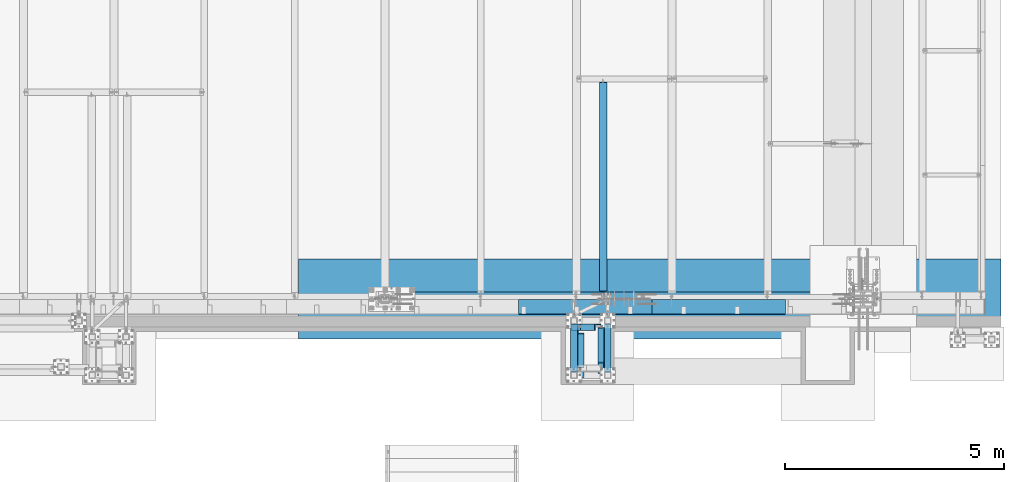
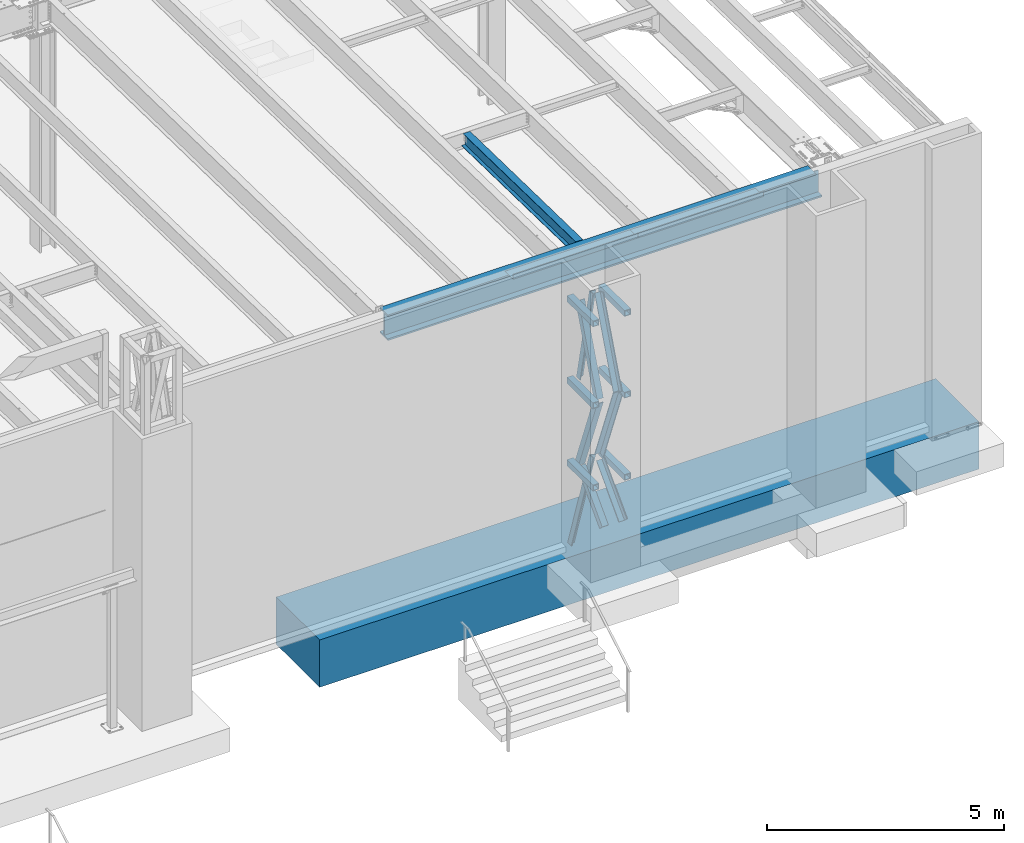
# One storey, part 1110 of 1763: 11 beams, 8 members, 4 elements without a shape of their own.
"""IFC2X3 building model written with IfcOpenShell, lengths in millimetres."""

from ifc_helpers import new_model, si_unit, frame, origin_with_axes, place, context, subcontext, project, spatial, faceted_brep, material, type_object, element, aggregate, save


model = new_model("IFC2X3")

# Units and contexts
model_context = context("Model", 3, precision=1e-05, world=origin_with_axes())
body_context = subcontext(model_context, "Body", "Model", "MODEL_VIEW")
ifc_project = project(units=[si_unit("LENGTHUNIT", "METRE", prefix="MILLI"), si_unit("AREAUNIT", "SQUARE_METRE"), si_unit("VOLUMEUNIT", "CUBIC_METRE"), si_unit("MASSUNIT", "GRAM", prefix="KILO"), si_unit("TIMEUNIT", "SECOND"), si_unit("PLANEANGLEUNIT", "RADIAN"), si_unit("SOLIDANGLEUNIT", "STERADIAN"), si_unit("THERMODYNAMICTEMPERATUREUNIT", "DEGREE_CELSIUS"), si_unit("LUMINOUSINTENSITYUNIT", "LUMEN")], contexts=[model_context])

# Site, building, storey
site_placement = place(None, origin_with_axes())
site = spatial("IfcSite", under=ifc_project, at=site_placement, CompositionType="ELEMENT")
building_placement = place(site_placement, origin_with_axes())
building = spatial("IfcBuilding", under=site, at=building_placement, Name="Undefined", CompositionType="ELEMENT")
storey_placement = place(building_placement, origin_with_axes())
storey = spatial("IfcBuildingStorey", under=building, at=storey_placement, Name="Undefined", CompositionType="ELEMENT", Elevation=0.0)

# Assembly, members, beams
assembly_1_placement = place(storey_placement, origin_with_axes())
assembly_1 = element("IfcElementAssembly", 1, at=assembly_1_placement, inside=storey, Name="FRAME", AssemblyPlace="NOTDEFINED", PredefinedType="RIGID_FRAME")
ifc_material_1 = material(Name="STEEL/A36")
member_type = type_object("IfcMemberType", Name="L6X6X7/8", PredefinedType="NOTDEFINED")
member_1_placement = place(assembly_1_placement, frame((-30406.4122248674, -14360.5242675181, 9325.96736126562), z_axis=(0.0, -1.0, 0.0), x_axis=(0.147752139006393, 0.0, 0.989024421042795)))
member_1 = element("IfcMember", 2, at=member_1_placement, type_object=member_type, material=ifc_material_1, Name="V. BRACE", ObjectType="L6X6X7/8", context=body_context, shape_type="Brep", body=[
    faceted_brep([(9.09494701772928e-13, 76.2000000000007, -76.2000000000844), (0.0, 76.2000000000007, 76.2000000000771), (2127.3818867065, 76.2000000039116, 76.2000000000007), (2127.3818867065, 76.2000000039116, -76.2000000000007), (0.0, 53.9750000000004, 76.2000000000771), (2127.3818867065, 53.9750000039785, 76.2000000000007), (1.81898940354586e-12, 53.9750000000004, -53.9750000000604), (2127.3818867065, 53.9750000039785, -53.9750000000004), (1.81898940354586e-12, -76.2000000000007, -53.9750000000604), (2127.38188670648, -76.1999999956752, -53.9750000000004), (9.09494701772928e-13, -76.2000000000007, -76.2000000000844), (2127.38188670648, -76.1999999956752, -76.2000000000007)], [[[0, 1, 2, 3]], [[1, 4, 5, 2]], [[4, 6, 7, 5]], [[6, 8, 9, 7]], [[8, 10, 11, 9]], [[10, 0, 3, 11]], [[5, 7, 9, 11, 3, 2]], [[10, 8, 6, 4, 1, 0]]]),
])
member_2_placement = place(assembly_1_placement, frame((-30015.887127214, -15224.1242675181, 9354.542188), z_axis=(-1.0, 0.0, 0.0), x_axis=(0.0, 0.354716320047586, 0.934973974125429)))
member_2 = element("IfcMember", 3, at=member_2_placement, type_object=member_type, material=ifc_material_1, Name="V. BRACE", ObjectType="L6X6X7/8", context=body_context, shape_type="Brep", body=[
    faceted_brep([(1.81898940354586e-12, -76.2000000000007, -53.9750000000604), (9.09494701772928e-13, -76.2000000000007, -76.2000000000844), (2219.80276448099, -76.1999999997752, -76.1999999999971), (2219.80276448099, -76.1999999997752, -53.9750000000058), (1.81898940354586e-12, 53.9750000000004, -53.9750000000604), (2219.80276448098, 53.9750000001222, -53.9750000000058), (0.0, 53.9750000000004, 76.2000000000771), (2219.80276448098, 53.9750000001222, 76.1999999999971), (0.0, 76.2000000000007, 76.2000000000771), (2219.80276448098, 76.2000000001062, 76.1999999999971), (9.09494701772928e-13, 76.2000000000007, -76.2000000000844), (2219.80276448098, 76.2000000001062, -76.1999999999971)], [[[0, 1, 2, 3]], [[4, 0, 3, 5]], [[6, 4, 5, 7]], [[8, 6, 7, 9]], [[1, 0, 4, 6, 8, 10]], [[1, 10, 11, 2]], [[7, 5, 3, 2, 11, 9]], [[10, 8, 9, 11]]]),
])
member_3_placement = place(assembly_1_placement, frame((-30015.887127214, -14436.724, 7238.22190623797), z_axis=(-1.0, 0.0, 0.0), x_axis=(0.0, -0.357374206981423, 0.933961281951452)))
member_3 = element("IfcMember", 4, at=member_3_placement, type_object=member_type, material=ifc_material_1, Name="V. BRACE", ObjectType="L6X6X7/8", context=body_context, shape_type="Brep", body=[
    faceted_brep([(1.81898940354586e-12, -76.2000000000007, -53.9750000000604), (9.09494701772928e-13, -76.2000000000007, -76.2000000000844), (2203.29349780015, -76.2000000014305, -76.1999999999971), (2203.29349780015, -76.2000000014305, -53.9750000000058), (1.81898940354586e-12, 53.9750000000004, -53.9750000000604), (2203.29349780012, 53.9749999985361, -53.9750000000058), (0.0, 53.9750000000004, 76.2000000000771), (2203.29349780012, 53.9749999985361, 76.1999999999971), (0.0, 76.2000000000007, 76.2000000000771), (2203.29349780012, 76.1999999985292, 76.1999999999971), (9.09494701772928e-13, 76.2000000000007, -76.2000000000844), (2203.29349780012, 76.1999999985292, -76.1999999999971)], [[[0, 1, 2, 3]], [[4, 0, 3, 5]], [[6, 4, 5, 7]], [[8, 6, 7, 9]], [[1, 0, 4, 6, 8, 10]], [[1, 10, 11, 2]], [[7, 5, 3, 2, 11, 9]], [[10, 8, 9, 11]]]),
])
member_4_placement = place(assembly_1_placement, frame((-30482.6122248702, -15224.1242675181, 9354.542188), z_axis=(1.0, 0.0, 0.0), x_axis=(0.0, 0.354716320047586, 0.934973974125429)))
member_4 = element("IfcMember", 5, at=member_4_placement, type_object=member_type, material=ifc_material_1, Name="V. BRACE", ObjectType="L6X6X7/8", context=body_context, shape_type="Brep", body=[
    faceted_brep([(9.09494701772928e-13, 76.2000000000007, -76.2000000000844), (0.0, 76.2000000000007, 76.2000000000771), (2219.80276448098, 76.2000000001062, 76.1999999999971), (2219.80276448098, 76.2000000001062, -76.1999999999971), (0.0, 53.9750000000004, 76.2000000000771), (2219.80276448098, 53.9750000001222, 76.1999999999971), (1.81898940354586e-12, 53.9750000000004, -53.9750000000604), (2219.80276448098, 53.9750000001222, -53.9750000000058), (1.81898940354586e-12, -76.2000000000007, -53.9750000000604), (2219.80276448099, -76.1999999997752, -53.9750000000058), (9.09494701772928e-13, -76.2000000000007, -76.2000000000844), (2219.80276448099, -76.1999999997752, -76.1999999999971)], [[[0, 1, 2, 3]], [[1, 4, 5, 2]], [[4, 6, 7, 5]], [[6, 8, 9, 7]], [[8, 10, 11, 9]], [[10, 0, 3, 11]], [[5, 7, 9, 11, 3, 2]], [[10, 8, 6, 4, 1, 0]]]),
])
member_5_placement = place(assembly_1_placement, frame((-30482.6122248702, -14436.724, 7238.22190623797), z_axis=(1.0, 0.0, 0.0), x_axis=(0.0, -0.357374206981423, 0.933961281951452)))
member_5 = element("IfcMember", 6, at=member_5_placement, type_object=member_type, material=ifc_material_1, Name="V. BRACE", ObjectType="L6X6X7/8", context=body_context, shape_type="Brep", body=[
    faceted_brep([(1.81898940354586e-12, -76.2000000000007, -53.9750000000604), (9.09494701772928e-13, -76.2000000000007, -76.2000000000844), (2203.29349780015, -76.2000000014305, -76.1999999999971), (2203.29349780015, -76.2000000014305, -53.9750000000058), (1.81898940354586e-12, 53.9750000000004, -53.9750000000604), (2203.29349780012, 53.9749999985361, -53.9750000000058), (0.0, 53.9750000000004, 76.2000000000771), (2203.29349780012, 53.9749999985361, 76.1999999999971), (0.0, 76.2000000000007, 76.2000000000771), (2203.29349780012, 76.1999999985292, 76.1999999999971), (9.09494701772928e-13, 76.2000000000007, -76.2000000000844), (2203.29349780012, 76.1999999985292, -76.1999999999971)], [[[0, 1, 2, 3]], [[4, 0, 3, 5]], [[6, 4, 5, 7]], [[8, 6, 7, 9]], [[1, 0, 4, 6, 8, 10]], [[1, 10, 11, 2]], [[7, 5, 3, 2, 11, 9]], [[10, 8, 9, 11]]]),
])
member_6_placement = place(assembly_1_placement, frame((-30015.887127214, -15452.7242675181, 6184.89897423299), z_axis=(-1.0, 0.0, 0.0), x_axis=(0.0, 0.691217150059911, 0.722647114062635)))
member_6 = element("IfcMember", 7, at=member_6_placement, type_object=member_type, material=ifc_material_1, Name="V. BRACE", ObjectType="L6X6X7/8", context=body_context, shape_type="Brep", body=[
    faceted_brep([(1.81898940354586e-12, -76.2000000000007, -53.9750000000604), (9.09494701772928e-13, -76.2000000000007, -76.2000000000844), (1385.03092654575, -76.1999999994277, -76.1999999999971), (1385.03092654575, -76.1999999994277, -53.9750000000058), (1.81898940354586e-12, 53.9750000000004, -53.9750000000604), (1385.0309265457, 53.9750000005115, -53.9750000000058), (0.0, 53.9750000000004, 76.2000000000771), (1385.0309265457, 53.9750000005115, 76.1999999999971), (0.0, 76.2000000000007, 76.2000000000771), (1385.03092654569, 76.2000000005009, 76.1999999999971), (9.09494701772928e-13, 76.2000000000007, -76.2000000000844), (1385.03092654569, 76.2000000005009, -76.1999999999971)], [[[0, 1, 2, 3]], [[4, 0, 3, 5]], [[6, 4, 5, 7]], [[8, 6, 7, 9]], [[1, 0, 4, 6, 8, 10]], [[1, 10, 11, 2]], [[7, 5, 3, 2, 11, 9]], [[10, 8, 9, 11]]]),
])
member_7_placement = place(assembly_1_placement, frame((-30482.6122248702, -15452.7238092148, 6184.9), z_axis=(1.0, 0.0, 0.0), x_axis=(0.0, 0.691217150059911, 0.722647114062635)))
member_7 = element("IfcMember", 8, at=member_7_placement, type_object=member_type, material=ifc_material_1, Name="V. BRACE", ObjectType="L6X6X7/8", context=body_context, shape_type="Brep", body=[
    faceted_brep([(1.81898940354586e-12, -76.2000000000007, -53.9750000000604), (9.09494701772928e-13, -76.2000000000007, -76.2000000000844), (1385.02986859929, -76.2000000005319, -76.1999999999971), (1385.02986859929, -76.2000000005319, -53.9750000000058), (1.81898940354586e-12, 53.9750000000004, -53.9750000000604), (1385.02986859926, 53.9749999994528, -53.9750000000058), (0.0, 53.9750000000004, 76.2000000000771), (1385.02986859926, 53.9749999994528, 76.1999999999971), (0.0, 76.2000000000007, 76.2000000000771), (1385.02986859925, 76.1999999994478, 76.1999999999971), (9.09494701772928e-13, 76.2000000000007, -76.2000000000844), (1385.02986859925, 76.1999999994478, -76.1999999999971)], [[[0, 1, 2, 3]], [[4, 0, 3, 5]], [[6, 4, 5, 7]], [[8, 6, 7, 9]], [[1, 0, 4, 6, 8, 10]], [[1, 10, 11, 2]], [[7, 5, 3, 2, 11, 9]], [[10, 8, 9, 11]]]),
])
member_8_placement = place(assembly_1_placement, frame((-30635.0122736983, -14360.5242675181, 5067.30000004768), z_axis=(0.0, -1.0, 0.0), x_axis=(0.24575404812011, 0.0, 0.969332217473751)))
member_8 = element("IfcMember", 9, at=member_8_placement, type_object=member_type, material=ifc_material_1, Name="V. BRACE", ObjectType="L6X6X7/8", context=body_context, shape_type="Brep", body=[
    faceted_brep([(58.6244028822784, 76.1999999994587, -76.2000000000007), (58.6244028822784, 76.1999999994587, 76.2000000000007), (2209.86127146497, 76.1999999862164, 76.2000000000007), (2209.86127146497, 76.1999999862164, -76.2000000000007), (58.6261393079949, 53.9749999995111, 76.2000000000007), (2209.86127146496, 53.9749999862543, 76.2000000000007), (58.6261393079949, 53.9749999995111, -53.9750000000004), (2209.86127146496, 53.9749999862543, -53.9750000000004), (58.6363098015081, -76.2000000002299, -53.9750000000004), (2209.8612714649, -76.2000000134722, -53.9750000000004), (58.6363098015081, -76.2000000002299, -76.2000000000007), (2209.8612714649, -76.2000000134722, -76.2000000000007)], [[[0, 1, 2, 3]], [[1, 4, 5, 2]], [[4, 6, 7, 5]], [[6, 8, 9, 7]], [[8, 10, 11, 9]], [[10, 0, 3, 11]], [[5, 7, 9, 11, 3, 2]], [[10, 8, 6, 4, 1, 0]]]),
])
ifc_material_2 = material()
beam_type_1 = type_object("IfcBeamType", Name="HSS6X6X5/8", PredefinedType="NOTDEFINED")
beam_1_placement = place(assembly_1_placement, frame((-29863.4872248702, -15452.7242675181, 11430.0), z_axis=(0.0, 0.0, 1.0), x_axis=(0.0, 1.0, 0.0)))
beam_1 = element("IfcBeam", 10, at=beam_1_placement, type_object=beam_type_1, material=ifc_material_2, Name="BEAM", ObjectType="HSS6X6X5/8", context=body_context, shape_type="Brep", body=[
    faceted_brep([(76.1999511718459, 60.3250000000007, -60.3250000000007), (76.1999511718459, -60.3250000000007, -60.3250000000007), (1168.4, -60.3249999999971, -60.3250000000007), (1168.4, 60.3249999999971, -60.3250000000007), (76.1999511718459, -60.3250000000007, 60.3250000000007), (1168.4, -60.3249999999971, 60.3250000000007), (76.1999511718459, 60.3250000000007, 60.3250000000007), (1168.4, 60.3249999999971, 60.3250000000007), (76.1999511718459, 76.2000000000007, -76.2000000000007), (76.1999511718459, 76.2000000000007, 76.2000000000007), (1168.4, 76.1999999999971, 76.2000000000007), (1168.4, 76.1999999999971, -76.2000000000007), (76.1999511718459, -76.2000000000007, 76.2000000000007), (1168.4, -76.1999999999971, 76.2000000000007), (76.1999511718459, -76.2000000000007, -76.2000000000007), (1168.4, -76.1999999999971, -76.2000000000007)], [[[0, 1, 2, 3]], [[1, 4, 5, 2]], [[4, 6, 7, 5]], [[6, 0, 3, 7]], [[8, 9, 10, 11]], [[9, 12, 13, 10]], [[12, 14, 15, 13]], [[14, 8, 11, 15]], [[13, 15, 11, 10], [5, 7, 3, 2]], [[14, 12, 9, 8], [6, 4, 1, 0]]]),
])
beam_2_placement = place(assembly_1_placement, frame((-30635.0122248702, -15452.7242675181, 11430.0), z_axis=(0.0, 0.0, 1.0), x_axis=(0.0, 1.0, 0.0)))
beam_2 = element("IfcBeam", 11, at=beam_2_placement, type_object=beam_type_1, material=ifc_material_2, Name="BEAM", ObjectType="HSS6X6X5/8", context=body_context, shape_type="Brep", body=[
    faceted_brep([(76.1999511718459, 60.3250000000007, -60.3250000000007), (76.1999511718459, -60.3250000000007, -60.3250000000007), (1168.4, -60.3249999999971, -60.3250000000007), (1168.4, 60.3249999999971, -60.3250000000007), (76.1999511718459, -60.3250000000007, 60.3250000000007), (1168.4, -60.3249999999971, 60.3250000000007), (76.1999511718459, 60.3250000000007, 60.3250000000007), (1168.4, 60.3249999999971, 60.3250000000007), (76.1999511718459, 76.2000000000007, -76.2000000000007), (76.1999511718459, 76.2000000000007, 76.2000000000007), (1168.4, 76.1999999999971, 76.2000000000007), (1168.4, 76.1999999999971, -76.2000000000007), (76.1999511718459, -76.2000000000007, 76.2000000000007), (1168.4, -76.1999999999971, 76.2000000000007), (76.1999511718459, -76.2000000000007, -76.2000000000007), (1168.4, -76.1999999999971, -76.2000000000007)], [[[0, 1, 2, 3]], [[1, 4, 5, 2]], [[4, 6, 7, 5]], [[6, 0, 3, 7]], [[8, 9, 10, 11]], [[9, 12, 13, 10]], [[12, 14, 15, 13]], [[14, 8, 11, 15]], [[13, 15, 11, 10], [5, 7, 3, 2]], [[14, 12, 9, 8], [6, 4, 1, 0]]]),
])
beam_3_placement = place(assembly_1_placement, frame((-29863.4872248702, -15452.7242675181, 9325.9676945918), z_axis=(0.0, 0.0, 1.0), x_axis=(0.0, 1.0, 0.0)))
beam_3 = element("IfcBeam", 12, at=beam_3_placement, type_object=beam_type_1, material=ifc_material_2, Name="BEAM", ObjectType="HSS6X6X5/8", context=body_context, shape_type="Brep", body=[
    faceted_brep([(76.1999511718459, 60.3250000000007, -60.3250000000007), (76.1999511718459, -60.3250000000007, -60.3250000000007), (1168.4, -60.3249999999971, -60.3250000000007), (1168.4, 60.3249999999971, -60.3250000000007), (76.1999511718459, -60.3250000000007, 60.3250000000007), (1168.4, -60.3249999999971, 60.3250000000007), (76.1999511718459, 60.3250000000007, 60.3250000000007), (1168.4, 60.3249999999971, 60.3250000000007), (76.1999511718459, 76.2000000000007, -76.2000000000007), (76.1999511718459, 76.2000000000007, 76.2000000000007), (1168.4, 76.1999999999971, 76.2000000000007), (1168.4, 76.1999999999971, -76.2000000000007), (76.1999511718459, -76.2000000000007, 76.2000000000007), (1168.4, -76.1999999999971, 76.2000000000007), (76.1999511718459, -76.2000000000007, -76.2000000000007), (1168.4, -76.1999999999971, -76.2000000000007)], [[[0, 1, 2, 3]], [[1, 4, 5, 2]], [[4, 6, 7, 5]], [[6, 0, 3, 7]], [[8, 9, 10, 11]], [[9, 12, 13, 10]], [[12, 14, 15, 13]], [[14, 8, 11, 15]], [[13, 15, 11, 10], [5, 7, 3, 2]], [[14, 12, 9, 8], [6, 4, 1, 0]]]),
])
beam_4_placement = place(assembly_1_placement, frame((-30635.0122248702, -15452.7242675181, 9325.9676945918), z_axis=(0.0, 0.0, 1.0), x_axis=(0.0, 1.0, 0.0)))
beam_4 = element("IfcBeam", 13, at=beam_4_placement, type_object=beam_type_1, material=ifc_material_2, Name="BEAM", ObjectType="HSS6X6X5/8", context=body_context, shape_type="Brep", body=[
    faceted_brep([(76.1999511718459, 60.3250000000007, -60.3250000000007), (76.1999511718459, -60.3250000000007, -60.3250000000007), (1168.4, -60.3249999999971, -60.3250000000007), (1168.4, 60.3249999999971, -60.3250000000007), (76.1999511718459, -60.3250000000007, 60.3250000000007), (1168.4, -60.3249999999971, 60.3250000000007), (76.1999511718459, 60.3250000000007, 60.3250000000007), (1168.4, 60.3249999999971, 60.3250000000007), (76.1999511718459, 76.2000000000007, -76.2000000000007), (76.1999511718459, 76.2000000000007, 76.2000000000007), (1168.4, 76.1999999999971, 76.2000000000007), (1168.4, 76.1999999999971, -76.2000000000007), (76.1999511718459, -76.2000000000007, 76.2000000000007), (1168.4, -76.1999999999971, 76.2000000000007), (76.1999511718459, -76.2000000000007, -76.2000000000007), (1168.4, -76.1999999999971, -76.2000000000007)], [[[0, 1, 2, 3]], [[1, 4, 5, 2]], [[4, 6, 7, 5]], [[6, 0, 3, 7]], [[8, 9, 10, 11]], [[9, 12, 13, 10]], [[12, 14, 15, 13]], [[14, 8, 11, 15]], [[13, 15, 11, 10], [5, 7, 3, 2]], [[14, 12, 9, 8], [6, 4, 1, 0]]]),
])
beam_5_placement = place(assembly_1_placement, frame((-29863.487127214, -15452.7242675181, 7209.43271670378), z_axis=(0.0, 0.0, 1.0), x_axis=(0.0, 1.0, 0.0)))
beam_5 = element("IfcBeam", 14, at=beam_5_placement, type_object=beam_type_1, material=ifc_material_2, Name="BEAM", ObjectType="HSS6X6X5/8", context=body_context, shape_type="Brep", body=[
    faceted_brep([(76.1999511718459, 60.3250000000007, -60.3250000000007), (76.1999511718459, -60.3250000000007, -60.3250000000007), (1168.4, -60.3249999999971, -60.3250000000007), (1168.4, 60.3249999999971, -60.3250000000007), (76.1999511718459, -60.3250000000007, 60.3250000000007), (1168.4, -60.3249999999971, 60.3250000000007), (76.1999511718459, 60.3250000000007, 60.3250000000007), (1168.4, 60.3249999999971, 60.3250000000007), (76.1999511718459, 76.2000000000007, -76.2000000000007), (76.1999511718459, 76.2000000000007, 76.2000000000007), (1168.4, 76.1999999999971, 76.2000000000007), (1168.4, 76.1999999999971, -76.2000000000007), (76.1999511718459, -76.2000000000007, 76.2000000000007), (1168.4, -76.1999999999971, 76.2000000000007), (76.1999511718459, -76.2000000000007, -76.2000000000007), (1168.4, -76.1999999999971, -76.2000000000007)], [[[0, 1, 2, 3]], [[1, 4, 5, 2]], [[4, 6, 7, 5]], [[6, 0, 3, 7]], [[8, 9, 10, 11]], [[9, 12, 13, 10]], [[12, 14, 15, 13]], [[14, 8, 11, 15]], [[13, 15, 11, 10], [5, 7, 3, 2]], [[14, 12, 9, 8], [6, 4, 1, 0]]]),
])
beam_6_placement = place(assembly_1_placement, frame((-30635.012127214, -15452.7242675181, 7209.43271670378), z_axis=(0.0, 0.0, 1.0), x_axis=(0.0, 1.0, 0.0)))
beam_6 = element("IfcBeam", 15, at=beam_6_placement, type_object=beam_type_1, material=ifc_material_2, Name="BEAM", ObjectType="HSS6X6X5/8", context=body_context, shape_type="Brep", body=[
    faceted_brep([(76.1999511718459, 60.3250000000007, -60.3250000000007), (76.1999511718459, -60.3250000000007, -60.3250000000007), (1168.4, -60.3249999999971, -60.3250000000007), (1168.4, 60.3249999999971, -60.3250000000007), (76.1999511718459, -60.3250000000007, 60.3250000000007), (1168.4, -60.3249999999971, 60.3250000000007), (76.1999511718459, 60.3250000000007, 60.3250000000007), (1168.4, 60.3249999999971, 60.3250000000007), (76.1999511718459, 76.2000000000007, -76.2000000000007), (76.1999511718459, 76.2000000000007, 76.2000000000007), (1168.4, 76.1999999999971, 76.2000000000007), (1168.4, 76.1999999999971, -76.2000000000007), (76.1999511718459, -76.2000000000007, 76.2000000000007), (1168.4, -76.1999999999971, 76.2000000000007), (76.1999511718459, -76.2000000000007, -76.2000000000007), (1168.4, -76.1999999999971, -76.2000000000007)], [[[0, 1, 2, 3]], [[1, 4, 5, 2]], [[4, 6, 7, 5]], [[6, 0, 3, 7]], [[8, 9, 10, 11]], [[9, 12, 13, 10]], [[12, 14, 15, 13]], [[14, 8, 11, 15]], [[13, 15, 11, 10], [5, 7, 3, 2]], [[14, 12, 9, 8], [6, 4, 1, 0]]]),
])
aggregate(assembly_1, [member_1, member_2, member_3, member_4, member_5, member_6, member_7, member_8, beam_1, beam_2, beam_3, beam_4, beam_5, beam_6])

# Assembly, beam
assembly_2_placement = place(storey_placement, origin_with_axes())
assembly_2 = element("IfcElementAssembly", 16, at=assembly_2_placement, inside=storey, Name="BEAM", AssemblyPlace="NOTDEFINED", PredefinedType="RIGID_FRAME")
ifc_material_3 = material(Name="STEEL/A992")
beam_type_2 = type_object("IfcBeamType", Name="W14X30", PredefinedType="NOTDEFINED")
beam_7_placement = place(assembly_2_placement, frame((-29971.4372736983, -13719.6832017473, 12028.5259948851), z_axis=(0.0, 0.0209013539966291, 0.999781542838788), x_axis=(0.0, 0.999781542776098, -0.0209013569953182)))
beam_7 = element("IfcBeam", 17, at=beam_7_placement, type_object=beam_type_2, material=ifc_material_3, Name="BEAM", ObjectType="W14X30", context=body_context, shape_type="Brep", body=[
    faceted_brep([(31.7805704350394, -3.47516606478166, -166.687499999967), (31.9796993425189, -3.47494054939671, -176.212499999967), (187.045846926301, -3.47488736177547, -176.212499999881), (187.045846926389, -3.47511280885374, -166.687499999884), (187.045875138043, -85.7249999999985, -166.687499999884), (187.045875138048, -85.7249999999985, -176.212499999883), (5021.58919858319, 85.7249999999985, -166.687499997308), (5021.78832749067, 85.7249999999985, -176.212499997306), (187.045816269083, 85.7249999999985, -176.212499999881), (187.045816269081, 85.7249999999985, -166.687499999885), (187.045844480788, 3.47511270054383, -176.212499999881), (187.045844480874, 3.47488725346193, -166.687499999884), (31.9796993425189, 3.47505951291896, -176.212499999967), (31.7805704350394, 3.47483399753037, -166.687499999967), (31.7805704350394, 3.17499999999927, -166.687499999967), (5021.58919858319, 3.17499999999927, -166.687499997308), (179.205894262803, -3.17499999999927, 119.769227786494), (179.205894262803, 3.17499999999927, 119.769227786494), (174.34581474476, 3.17499999999927, 118.802497863904), (174.34581474476, -3.17499999999927, 118.802497863904), (183.326070730953, -3.17499999999927, 122.522241686973), (183.326070730953, 3.17499999999927, 122.522241686973), (186.079084631428, -3.17499999999927, 126.642418155128), (186.079084631428, 3.17499999999927, 126.642418155128), (187.045814554012, -3.17499999999927, 131.502497673173), (187.045814554012, 3.17499999999927, 131.502497673173), (187.045814553992, -85.7249999999985, 176.212500000081), (187.045814553992, 85.7249999999985, 176.212500000081), (187.045814553998, 85.7249999999985, 166.687500000082), (187.045814553998, 3.17499999999927, 166.687500000082), (187.045814553998, -3.17499999999927, 166.687500000082), (187.045814553998, -85.7249999999985, 166.687500000082), (4948.25444270103, 85.7249999999985, 166.687500002619), (4948.25444270103, 3.17499999999927, 166.687500002619), (25.8121387950687, 3.17499999999927, 118.802497863826), (4948.25444270103, 3.17499999999927, 156.902501503695), (4949.22117262362, 3.17499999999927, 152.04242198565), (4951.9741865241, 3.17499999999927, 147.922245517499), (4956.09436299226, 3.17499999999927, 145.169231617023), (4960.9544425103, 3.17499999999927, 144.202501694439), (5015.08975644325, 3.17499999999927, 144.202501694468), (25.8121387950687, -3.17499999999927, 118.802497863826), (4956.09436299226, -3.17499999999927, 145.169231617023), (4951.9741865241, -3.17499999999927, 147.922245517499), (4949.22117262362, -3.17499999999927, 152.04242198565), (4948.25444270103, -3.17499999999927, 156.902501503695), (4948.25444270103, -3.17499999999927, 166.687500002619), (31.7805704350394, -3.17499999999927, -166.687499999967), (5021.58919858319, -3.17499999999927, -166.687499997308), (5015.08975644325, -3.17499999999927, 144.202501694468), (4960.9544425103, -3.17499999999927, 144.202501694439), (4948.25444270103, -85.7249999999985, 166.687500002619), (4948.25444270102, -85.7249999999985, 176.212500002619), (4948.25444270102, 85.7249999999985, 176.212500002619), (5021.58919858319, -85.7249999999985, -166.687499997308), (5021.78832749067, -85.7249999999985, -176.212499997306)], [[[0, 1, 2, 3]], [[4, 3, 2, 5]], [[6, 7, 8, 9]], [[9, 8, 10, 11]], [[11, 10, 12, 13]], [[14, 15, 6, 9, 11, 13]], [[16, 17, 18, 19]], [[20, 21, 17, 16]], [[22, 23, 21, 20]], [[24, 25, 23, 22]], [[26, 27, 28, 29, 25, 24, 30, 31]], [[29, 28, 32, 33]], [[15, 14, 34, 18, 17, 21, 23, 25, 29, 33, 35, 36, 37, 38, 39, 40]], [[19, 18, 34, 41]], [[42, 43, 44, 45, 46, 30, 24, 22, 20, 16, 19, 41, 47, 48, 49, 50]], [[31, 30, 46, 51]], [[26, 31, 51, 52]], [[27, 26, 52, 53]], [[28, 27, 53, 32]], [[52, 51, 46, 45, 35, 33, 32, 53]], [[44, 36, 35, 45]], [[43, 37, 36, 44]], [[42, 38, 37, 43]], [[50, 39, 38, 42]], [[49, 40, 39, 50]], [[48, 54, 55, 7, 6, 15, 40, 49]], [[55, 54, 4, 5]], [[1, 12, 10, 8, 7, 55, 5, 2]], [[47, 41, 34, 14, 13, 12, 1, 0]], [[54, 48, 47, 0, 3, 4]]]),
])
aggregate(assembly_2, [beam_7])

# Assembly, beams
assembly_3_placement = place(storey_placement, origin_with_axes())
assembly_3 = element("IfcElementAssembly", 18, at=assembly_3_placement, inside=storey, Name="BEAM", AssemblyPlace="NOTDEFINED", PredefinedType="RIGID_FRAME")
beam_type_3 = type_object("IfcBeamType", PredefinedType="NOTDEFINED")
beam_8_placement = place(assembly_3_placement, frame((-27326.6622736984, -13728.6998186171, 12207.875), z_axis=(-1.0, 0.0, 0.0), x_axis=(0.0, -1.0, 0.0)))
beam_8 = element("IfcBeam", 19, at=beam_8_placement, type_object=beam_type_3, material=ifc_material_1, Name="BENT_PLATE", context=body_context, shape_type="Brep", body=[
    faceted_brep([(0.0, -3.17499999999927, -1523.99999999999), (0.0, -3.17499999999927, 1524.0), (0.0, 3.17499999999927, 1524.0), (0.0, 3.17499999999927, -1523.99999999999), (330.200016784669, 3.17499999999927, 1524.0), (330.200016784669, 3.17499999999927, -1524.0), (336.550018310547, -3.17499999999927, -1524.0), (336.550018310547, -3.17499999999927, 1524.0), (330.19998779297, 123.824998474123, 1524.0), (330.19998779297, 123.824998474123, -1524.0), (336.549987792969, 123.825000000001, 1524.0), (336.549987792969, 123.825000000001, -1524.0)], [[[0, 1, 2, 3]], [[3, 2, 4, 5]], [[1, 0, 6, 7]], [[5, 4, 8, 9]], [[4, 2, 1, 7, 10, 8]], [[7, 6, 11, 10]], [[6, 0, 3, 5, 9, 11]], [[10, 11, 9, 8]]]),
])
beam_9_placement = place(assembly_3_placement, frame((-30374.6622736984, -13728.6998186171, 12207.875), z_axis=(-1.0, 0.0, 0.0), x_axis=(0.0, -1.0, 0.0)))
beam_9 = element("IfcBeam", 20, at=beam_9_placement, type_object=beam_type_3, material=ifc_material_1, Name="BENT_PLATE", context=body_context, shape_type="Brep", body=[
    faceted_brep([(0.0, -3.17499999999927, -1523.99999999999), (0.0, -3.17499999999927, 1524.0), (0.0, 3.17499999999927, 1524.0), (0.0, 3.17499999999927, -1523.99999999999), (330.200016784669, 3.17499999999927, 1524.0), (330.200016784669, 3.17499999999927, -1524.0), (336.550018310547, -3.17499999999927, -1524.0), (336.550018310547, -3.17499999999927, 1524.0), (330.19998779297, 123.824998474123, 1524.0), (330.19998779297, 123.824998474123, -1524.0), (336.549987792969, 123.825000000001, 1524.0), (336.549987792969, 123.825000000001, -1524.0)], [[[0, 1, 2, 3]], [[3, 2, 4, 5]], [[1, 0, 6, 7]], [[5, 4, 8, 9]], [[4, 2, 1, 7, 10, 8]], [[7, 6, 11, 10]], [[6, 0, 3, 5, 9, 11]], [[10, 11, 9, 8]]]),
])

# Assembly, beam
assembly_4_placement = place(storey_placement, origin_with_axes())
assembly_4 = element("IfcElementAssembly", 21, at=assembly_4_placement, inside=storey, Name="STRIP FOOTING", AssemblyPlace="NOTDEFINED", PredefinedType="REINFORCEMENT_UNIT")
ifc_material_4 = material(Name="CONCRETE/5000")
beam_type_4 = type_object("IfcBeamType", PredefinedType="NOTDEFINED")
beam_10_placement = place(assembly_4_placement, frame((-36931.0372736983, -13716.0, 4419.6), z_axis=(0.0, 0.0, 1.0), x_axis=(1.0, 0.0, 0.0)))
beam_10 = element("IfcBeam", 22, at=beam_10_placement, type_object=beam_type_4, material=ifc_material_4, Name="STRIP FOOTING", context=body_context, shape_type="Brep", body=[
    faceted_brep([(0.0, 914.400000000001, -609.6), (0.0, 914.400000000001, 609.6), (16052.8, 914.4, 609.6), (16052.8, 914.4, -609.6), (0.0, -914.400000000001, 609.6), (16052.8, -914.4, 609.6), (0.0, -914.400000000001, -609.6), (16052.8, -914.4, -609.6)], [[[0, 1, 2, 3]], [[1, 4, 5, 2]], [[4, 6, 7, 5]], [[6, 0, 3, 7]], [[5, 7, 3, 2]], [[6, 4, 1, 0]]]),
])
aggregate(assembly_4, [beam_10])

# Beam
beam_type_5 = type_object("IfcBeamType", Name="W24X229", PredefinedType="NOTDEFINED")
beam_11_placement = place(assembly_3_placement, frame((-34949.8372736984, -13715.9998186171, 11874.5), z_axis=(0.0, 0.0, 1.0), x_axis=(1.0, 0.0, 0.0)))
beam_11 = element("IfcBeam", 23, at=beam_11_placement, type_object=beam_type_5, material=ifc_material_3, Name="BEAM", ObjectType="W24X229", context=body_context, shape_type="Brep", body=[
    faceted_brep([(10527.4317174188, -166.6875, 330.200000000001), (10527.4317174188, -166.6875, 285.75), (10527.4317174188, -11.90625, 285.75), (10527.4317174188, -11.90625, 279.399999808975), (10527.4317174188, 11.90625, 279.399999808975), (10527.4317174188, 11.90625, 285.75), (10527.4317174188, 166.6875, 285.75), (10527.4317174188, 166.6875, 330.200000000001), (10528.3984473414, -11.90625, 274.539920290928), (10528.3984473414, 11.90625, 274.539920290928), (10531.1514612419, -11.90625, 270.419743822775), (10531.1514612419, 11.90625, 270.419743822775), (10535.27163771, -11.90625, 267.666729922297), (10535.27163771, 11.90625, 267.666729922297), (10540.1317172281, -11.90625, 266.69999999971), (10540.1317172281, 11.90625, 266.69999999971), (10683.8750004999, -11.90625, 266.69999999971), (10683.8750047484, 11.90625, 266.69999999971), (114.300000000003, -166.6875, -330.200000000001), (114.300000000003, -166.6875, -285.75), (114.300000000003, -11.90625, -285.75), (114.300000000003, -11.90625, 285.75), (114.300000000003, -166.6875, 285.75), (114.300000000003, -166.6875, 330.200000000001), (114.299999999996, 166.6875, 330.200000000001), (114.299999999996, 166.6875, 285.75), (114.300000000003, 11.90625, 285.75), (114.300000000003, 11.90625, -285.75), (114.299999999996, 166.6875, -285.75), (114.299999999996, 166.6875, -330.200000000001), (10683.8750047484, 11.90625, -285.75), (10683.8750047484, 166.6875, -285.75), (10683.8750047484, 166.6875, -330.200000000001), (10683.8750047484, -166.6875, -330.200000000001), (10683.8750047484, -166.6875, -285.75), (10683.8750047484, -11.90625, -285.75)], [[[0, 1, 2, 3, 4, 5, 6, 7]], [[8, 9, 4, 3]], [[10, 11, 9, 8]], [[12, 13, 11, 10]], [[14, 15, 13, 12]], [[16, 17, 15, 14]], [[18, 19, 20, 21, 22, 23, 24, 25, 26, 27, 28, 29]], [[28, 27, 30, 31]], [[29, 28, 31, 32]], [[18, 29, 32, 33]], [[19, 18, 33, 34]], [[20, 19, 34, 35]], [[12, 10, 8, 3, 2, 21, 20, 35, 16, 14]], [[22, 21, 2, 1]], [[23, 22, 1, 0]], [[24, 23, 0, 7]], [[25, 24, 7, 6]], [[26, 25, 6, 5]], [[30, 27, 26, 5, 4, 9, 11, 13, 15, 17]], [[35, 34, 33, 32, 31, 30, 17, 16]]]),
])

aggregate(assembly_3, [beam_8, beam_9, beam_11])

save(model, "model.ifc")
